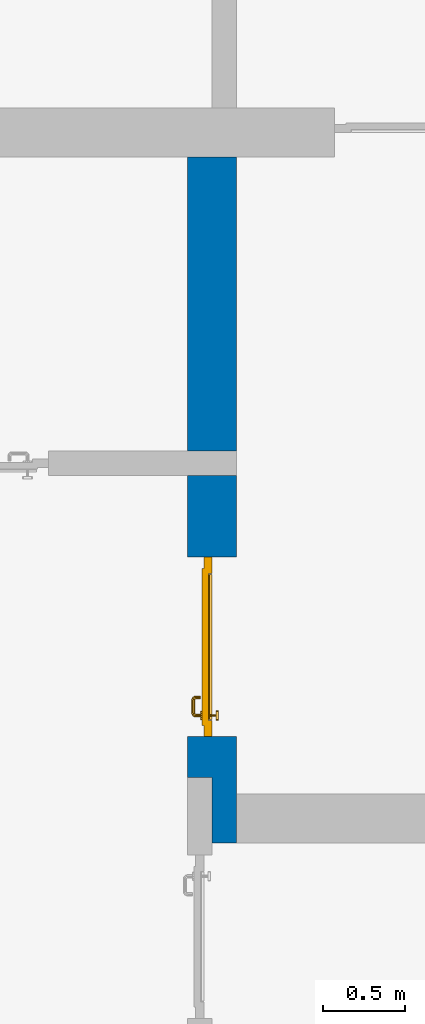
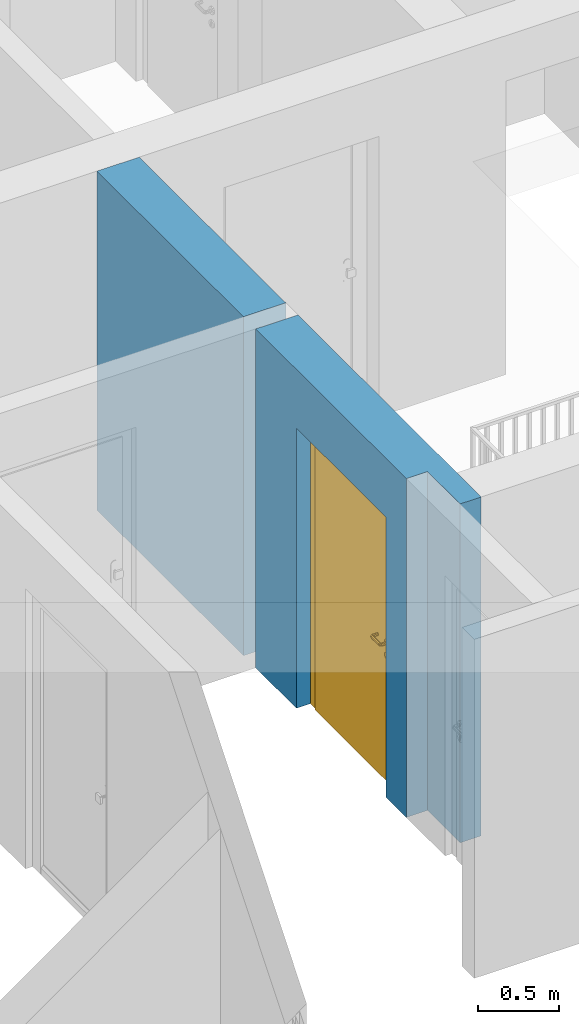
# One storey, part 13 of 54: 1 door, 1 wall, 1 opening.
"""IFC4 building model written with IfcOpenShell, lengths in metres."""

from ifc_helpers import new_model, entity, si_unit, converted_unit, derived_unit, direction, frame, origin_with_axes, place, context, subcontext, project, spatial, polygons, source, transform, mapped, material, type_object, element, fill, save


model = new_model("IFC4")

# Units and contexts
model_context = context("Model", 3, precision=1e-05, world=origin_with_axes(), true_north=direction((0.0, 1.0)))
body_context = subcontext(model_context, "Body", "Model", "MODEL_VIEW")
ifc_project = project(units=[si_unit("LENGTHUNIT", "METRE"), si_unit("AREAUNIT", "SQUARE_METRE"), si_unit("VOLUMEUNIT", "CUBIC_METRE"), converted_unit("PLANEANGLEUNIT", "DEGREE", entity("IfcPlaneAngleMeasure", 0.0174532925199), si_unit("PLANEANGLEUNIT", "RADIAN"), dimensions=[0, 0, 0, 0, 0, 0, 0]), converted_unit("TIMEUNIT", "Year", entity("IfcTimeMeasure", 31556926.0), si_unit("TIMEUNIT", "SECOND"), dimensions=[0, 0, 1, 0, 0, 0, 0]), si_unit("MASSUNIT", "GRAM", prefix="KILO"), si_unit("THERMODYNAMICTEMPERATUREUNIT", "DEGREE_CELSIUS"), si_unit("LUMINOUSINTENSITYUNIT", "LUMEN"), si_unit("ENERGYUNIT", "JOULE", prefix="MEGA"), derived_unit("THERMALCONDUCTANCEUNIT", [(si_unit("POWERUNIT", "WATT"), 1), (si_unit("LENGTHUNIT", "METRE"), -1), (si_unit("THERMODYNAMICTEMPERATUREUNIT", "KELVIN"), -1)]), derived_unit("SPECIFICHEATCAPACITYUNIT", [(si_unit("ENERGYUNIT", "JOULE"), 1), (si_unit("MASSUNIT", "GRAM", prefix="KILO"), -1), (si_unit("THERMODYNAMICTEMPERATUREUNIT", "KELVIN"), -1)]), derived_unit("MASSDENSITYUNIT", [(si_unit("MASSUNIT", "GRAM", prefix="KILO"), 1), (si_unit("VOLUMEUNIT", "CUBIC_METRE"), -1)])], contexts=[model_context])

# Site, building, storey
site_placement = place(None, origin_with_axes())
site = spatial("IfcSite", under=ifc_project, at=site_placement, CompositionType="ELEMENT")
building_placement = place(site_placement, origin_with_axes())
building = spatial("IfcBuilding", under=site, at=building_placement, CompositionType="ELEMENT")
storey_placement = place(building_placement, frame((0.0, 0.0, 6.29), z_axis=(0.0, 0.0, 1.0), x_axis=(1.0, 0.0, 0.0)))
storey = spatial("IfcBuildingStorey", under=building, at=storey_placement, Name="2. Geschoss", CompositionType="ELEMENT", Elevation=6.29)

# Wall, opening, door
ifc_material = material()
wall_type = type_object("IfcWallType", Name="300", PredefinedType="NOTDEFINED")
wall_placement = place(storey_placement, frame((-5.2421993804, -2.52881223104, 0.0), z_axis=(0.0, 0.0, 1.0), x_axis=(0.0, 1.0, 0.0)))
wall = element("IfcWall", 1, at=wall_placement, inside=storey, type_object=wall_type, material=ifc_material, Name="Wand-001", PredefinedType="NOTDEFINED", context=body_context, shape_type="Tessellation", body=[
    polygons([(0.35, -0.15, 2.1), (1.45, -0.15, 2.1), (1.45, -0.3, 2.1), (0.35, -0.3, 2.1), (0.35, 0.0, 2.1), (1.45, 0.0, 2.1), (1.45, -0.15, 0.0), (1.45, -0.3, 0.0), (1.95, -0.3, 2.54), (-0.3, -0.3, 2.54), (-0.3, -0.3, 0.0), (0.35, -0.3, 0.0), (1.95, -0.3, 0.0), (0.35, -0.15, 0.0), (0.35, 0.0, 0.0), (0.1, 0.0, 0.0), (0.1, 0.0, 2.54), (1.95, 0.0, 2.54), (1.95, 0.0, 0.0), (1.45, 0.0, 0.0), (-0.3, -0.15, 2.54), (0.1, -0.15, 2.54), (-0.3, -0.15, 0.0), (0.1, -0.15, 0.0)], [[[1, 2, 3, 4]], [[2, 1, 5, 6]], [[2, 7, 8, 3]], [[9, 10, 11, 12, 4, 3, 8, 13]], [[14, 1, 4, 12]], [[1, 14, 15, 5]], [[5, 15, 16, 17, 18, 19, 20, 6]], [[7, 2, 6, 20]], [[7, 20, 19, 13, 8]], [[21, 10, 9, 18, 17, 22]], [[21, 23, 11, 10]], [[15, 14, 12, 11, 23, 24, 16]], [[9, 13, 19, 18]], [[17, 16, 24, 22]], [[22, 24, 23, 21]]], closed=True),
    polygons([(3.9, 0.0, 0.0), (3.9, 0.0, 2.54), (3.9, -0.3, 2.54), (3.9, -0.3, 0.0), (2.1, 0.0, 0.0), (2.1, 0.0, 2.54), (2.1, -0.3, 2.54), (2.1, -0.3, 0.0)], [[[1, 2, 3, 4]], [[5, 6, 2, 1]], [[6, 7, 3, 2]], [[4, 3, 7, 8]], [[5, 1, 4, 8]], [[8, 7, 6, 5]]], closed=True),
])
opening_placement = place(wall_placement, frame((0.9, 0.0, 0.0), z_axis=(0.0, 0.0, 1.0), x_axis=(1.0, 0.0, 0.0)))
opening = element("IfcOpeningElement", 2, at=opening_placement, cuts=wall, context=body_context, identifier="Reference", shape_type="Tessellation", body=[
    polygons([(0.55, -0.15, 0.0), (0.55, -0.15, 2.1), (0.55, -0.301, 2.1), (0.55, -0.301, 0.0), (0.55, 0.001, 0.0), (0.55, 0.001, 2.1), (-0.55, -0.15, 2.1), (-0.55, -0.301, 2.1), (-0.55, 0.001, 2.1), (-0.55, -0.301, 0.0), (-0.55, -0.15, 0.0), (-0.55, 0.001, 0.0)], [[[1, 2, 3, 4]], [[2, 1, 5, 6]], [[7, 8, 3, 2, 6, 9]], [[8, 10, 4, 3]], [[1, 4, 10, 11, 12, 5]], [[6, 5, 12, 9]], [[7, 11, 10, 8]], [[11, 7, 9, 12]]], closed=True),
])
door_type = type_object("IfcDoorType", Name="Eingang 01 1-Fl 26", OperationType="SINGLE_SWING_RIGHT", PredefinedType="DOOR")
shared_shape = source(origin_with_axes(), body_context, "Body", "Tessellation", [
    polygons([(0.55, -0.05, 0.0), (0.55, -0.03, 0.0), (0.55, -0.03, 2.1), (0.55, -0.05, 2.1), (0.45, -0.05, 0.0), (0.45, -0.03, 0.0), (0.45, -0.03, 2.0), (0.1301, -0.03, 2.0), (0.0001, -0.03, 2.0), (-0.45, -0.03, 2.0), (-0.45, -0.03, 0.0), (-0.55, -0.03, 0.0), (-0.55, -0.03, 2.1), (-0.55, -0.05, 2.1), (-0.55, -0.05, 0.0), (-0.45, -0.05, 0.0), (-0.45, -0.05, 2.0), (0.0001, -0.05, 2.0), (0.1301, -0.05, 2.0), (0.45, -0.05, 2.0)], [[[1, 2, 3, 4]], [[5, 6, 2, 1]], [[2, 6, 7, 8, 9, 10, 11, 12, 13, 3]], [[4, 3, 13, 14]], [[1, 4, 14, 15, 16, 17, 18, 19, 20, 5]], [[20, 7, 6, 5]], [[19, 8, 7, 20]], [[18, 9, 8, 19]], [[17, 10, 9, 18]], [[16, 11, 10, 17]], [[15, 12, 11, 16]], [[14, 13, 12, 15]]], closed=True),
    polygons([(0.55, -0.03, 0.0), (0.55, 0.0, 0.0), (0.55, 0.0, 2.1), (0.55, -0.03, 2.1), (0.48, -0.03, 0.0), (0.48, 0.0, 0.0), (0.48, 0.0, 2.03), (0.1001, 0.0, 2.03), (0.0301, 0.0, 2.03), (-0.48, 0.0, 2.03), (-0.48, 0.0, 0.0), (-0.55, 0.0, 0.0), (-0.55, 0.0, 2.1), (-0.55, -0.03, 2.1), (-0.55, -0.03, 0.0), (-0.48, -0.03, 0.0), (-0.48, -0.03, 2.03), (0.0301, -0.03, 2.03), (0.1001, -0.03, 2.03), (0.48, -0.03, 2.03)], [[[1, 2, 3, 4]], [[5, 6, 2, 1]], [[2, 6, 7, 8, 9, 10, 11, 12, 13, 3]], [[4, 3, 13, 14]], [[1, 4, 14, 15, 16, 17, 18, 19, 20, 5]], [[20, 7, 6, 5]], [[19, 8, 7, 20]], [[18, 9, 8, 19]], [[17, 10, 9, 18]], [[16, 11, 10, 17]], [[15, 12, 11, 16]], [[14, 13, 12, 15]]], closed=True),
    polygons([(0.48, 0.01, 0.0), (-0.48, 0.01, 0.0), (-0.48, 0.01, 2.03), (0.48, 0.01, 2.03), (0.48, -0.03, 0.0), (-0.48, -0.03, 0.0), (-0.48, -0.03, 2.03), (0.48, -0.03, 2.03)], [[[1, 2, 3, 4]], [[2, 1, 5, 6]], [[3, 2, 6, 7]], [[4, 3, 7, 8]], [[1, 4, 8, 5]], [[6, 5, 8, 7]]], closed=True),
    polygons([(0.445, -0.05, 0.0), (0.445, -0.05, 0.05), (-0.445, -0.05, 0.05), (-0.445, -0.05, 0.0), (0.445, -0.03, 0.0), (0.445, -0.03, 0.07), (0.445, -0.035, 0.07), (-0.445, -0.035, 0.07), (-0.445, -0.03, 0.07), (-0.445, -0.03, 0.0)], [[[1, 2, 3, 4]], [[1, 5, 6, 7, 2]], [[2, 7, 8, 3]], [[4, 3, 8, 9, 10]], [[5, 1, 4, 10]], [[6, 5, 10, 9]], [[7, 6, 9, 8]]], closed=True),
    polygons([(-0.4335, 0.02, 1.0733826859), (-0.4335, 0.0199, 1.0733826859), (-0.42, 0.0199, 1.077), (-0.42, 0.02, 1.077), (-0.443382685902, 0.02, 1.0635), (-0.443382685902, 0.0199, 1.0635), (-0.4335, 0.0101, 1.0733826859), (-0.42, 0.0101, 1.077), (-0.4065, 0.0199, 1.0733826859), (-0.4065, 0.02, 1.0733826859), (-0.396617314098, 0.02, 1.0635), (-0.393, 0.02, 1.05), (-0.396617314098, 0.02, 1.0365), (-0.4065, 0.02, 1.0266173141), (-0.42, 0.02, 1.023), (-0.4335, 0.02, 1.0266173141), (-0.443382685902, 0.02, 1.0365), (-0.447, 0.02, 1.05), (-0.447, 0.0199, 1.05), (-0.443382685902, 0.0101, 1.0635), (-0.4335, 0.01, 1.0733826859), (-0.42, 0.01, 1.077), (-0.4065, 0.0101, 1.0733826859), (-0.396617314098, 0.0199, 1.0635), (-0.393, 0.0199, 1.05), (-0.396617314098, 0.0199, 1.0365), (-0.4065, 0.0199, 1.0266173141), (-0.42, 0.0199, 1.023), (-0.4335, 0.0199, 1.0266173141), (-0.443382685902, 0.0199, 1.0365), (-0.447, 0.0101, 1.05), (-0.443382685902, 0.01, 1.0635), (-0.447, 0.01, 1.05), (-0.443382685902, 0.01, 1.0365), (-0.4335, 0.01, 1.0266173141), (-0.42, 0.01, 1.023), (-0.4065, 0.01, 1.0266173141), (-0.396617314098, 0.01, 1.0365), (-0.393, 0.01, 1.05), (-0.396617314098, 0.01, 1.0635), (-0.4065, 0.01, 1.0733826859), (-0.396617314098, 0.0101, 1.0635), (-0.393, 0.0101, 1.05), (-0.396617314098, 0.0101, 1.0365), (-0.4065, 0.0101, 1.0266173141), (-0.42, 0.0101, 1.023), (-0.4335, 0.0101, 1.0266173141), (-0.443382685902, 0.0101, 1.0365)], [[[1, 2, 3, 4]], [[5, 6, 2, 1]], [[2, 7, 8, 3]], [[4, 3, 9, 10]], [[4, 10, 11, 12, 13, 14, 15, 16, 17, 18, 5, 1]], [[18, 19, 6, 5]], [[6, 20, 7, 2]], [[7, 21, 22, 8]], [[3, 8, 23, 9]], [[10, 9, 24, 11]], [[11, 24, 25, 12]], [[12, 25, 26, 13]], [[13, 26, 27, 14]], [[14, 27, 28, 15]], [[15, 28, 29, 16]], [[16, 29, 30, 17]], [[17, 30, 19, 18]], [[19, 31, 20, 6]], [[20, 32, 21, 7]], [[22, 21, 32, 33, 34, 35, 36, 37, 38, 39, 40, 41]], [[8, 22, 41, 23]], [[9, 23, 42, 24]], [[24, 42, 43, 25]], [[25, 43, 44, 26]], [[26, 44, 45, 27]], [[27, 45, 46, 28]], [[28, 46, 47, 29]], [[29, 47, 48, 30]], [[30, 48, 31, 19]], [[31, 33, 32, 20]], [[48, 34, 33, 31]], [[47, 35, 34, 48]], [[46, 36, 35, 47]], [[45, 37, 36, 46]], [[44, 38, 37, 45]], [[43, 39, 38, 44]], [[42, 40, 39, 43]], [[23, 41, 40, 42]]], closed=True),
    polygons([(-0.412532169224, 0.019, 0.959692280177), (-0.415, 0.019, 0.9544), (-0.415, 0.019, 0.952886751346), (-0.397569942042, 0.019, 0.96295), (-0.40705, 0.019, 0.972430057958), (-0.413279754556, 0.019, 0.961639806549), (-0.412532169224, 0.02, 0.959692280177), (-0.415, 0.02, 0.9544), (-0.415, 0.02, 0.952886751346), (-0.415, 0.02, 0.95), (-0.415, 0.02, 0.947113248654), (-0.415, 0.02, 0.941339745962), (-0.415, 0.02, 0.9375), (-0.415, 0.019, 0.9375), (-0.415, 0.019, 0.941339745962), (-0.415, 0.019, 0.947113248654), (-0.415, 0.019, 0.95), (-0.3941, 0.019, 0.95), (-0.397483339502, 0.019, 0.963), (-0.407, 0.019, 0.972516660498), (-0.414624817685, 0.019, 0.965143815798), (-0.42, 0.019, 0.9759), (-0.42, 0.019, 0.967425445323), (-0.414624817685, 0.02, 0.965143815798), (-0.413279754556, 0.02, 0.961639806549), (-0.40655, 0.02, 0.973296083362), (-0.396703916638, 0.02, 0.96345), (-0.3931, 0.02, 0.95), (-0.396703916638, 0.02, 0.93655), (-0.40655, 0.02, 0.926703916638), (-0.42, 0.02, 0.9231), (-0.42, 0.02, 0.9325), (-0.416464466094, 0.02, 0.933964466094), (-0.416464466094, 0.019, 0.933964466094), (-0.40705, 0.019, 0.927569942042), (-0.42, 0.019, 0.9325), (-0.42, 0.019, 0.9241), (-0.397569942042, 0.019, 0.93705), (-0.394, 0.019, 0.95), (-0.397483339502, 0.0189, 0.963), (-0.407, 0.0189, 0.972516660498), (-0.42, 0.019, 0.976), (-0.425375182315, 0.019, 0.965143815798), (-0.43295, 0.019, 0.972430057958), (-0.426720245444, 0.019, 0.961639806549), (-0.42, 0.02, 0.967425445323), (-0.42, 0.02, 0.9769), (-0.396617314098, 0.02, 0.9635), (-0.4065, 0.02, 0.973382685902), (-0.393, 0.02, 0.95), (-0.396617314098, 0.02, 0.9365), (-0.4065, 0.02, 0.926617314098), (-0.43345, 0.02, 0.926703916638), (-0.425, 0.02, 0.941339745962), (-0.425, 0.02, 0.9375), (-0.423535533906, 0.02, 0.933964466094), (-0.42, 0.02, 0.923), (-0.423535533906, 0.019, 0.933964466094), (-0.425, 0.019, 0.9375), (-0.425, 0.019, 0.941339745962), (-0.43295, 0.019, 0.927569942042), (-0.42, 0.019, 0.924), (-0.407, 0.019, 0.927483339502), (-0.397483339502, 0.019, 0.937), (-0.394, 0.0189, 0.95), (-0.397483339502, 0.0101, 0.963), (-0.407, 0.0101, 0.972516660498), (-0.42, 0.0189, 0.976), (-0.433, 0.019, 0.972516660498), (-0.425375182315, 0.02, 0.965143815798), (-0.427467830776, 0.019, 0.959692280177), (-0.442430057958, 0.019, 0.96295), (-0.425, 0.019, 0.952886751346), (-0.425, 0.019, 0.9544), (-0.427467830776, 0.02, 0.959692280177), (-0.426720245444, 0.02, 0.961639806549), (-0.43345, 0.02, 0.973296083362), (-0.42, 0.02, 0.977), (-0.396617314098, 0.0199, 0.9635), (-0.4065, 0.0199, 0.973382685902), (-0.393, 0.0199, 0.95), (-0.396617314098, 0.0199, 0.9365), (-0.4065, 0.0199, 0.926617314098), (-0.443296083362, 0.02, 0.93655), (-0.425, 0.02, 0.947113248654), (-0.425, 0.02, 0.9544), (-0.425, 0.019, 0.95), (-0.425, 0.019, 0.947113248654), (-0.425, 0.02, 0.95), (-0.425, 0.02, 0.952886751346), (-0.4335, 0.02, 0.926617314098), (-0.42, 0.0199, 0.923), (-0.442430057958, 0.019, 0.93705), (-0.433, 0.019, 0.927483339502), (-0.42, 0.0189, 0.924), (-0.407, 0.0189, 0.927483339502), (-0.397483339502, 0.0189, 0.937), (-0.394, 0.0101, 0.95), (-0.397483339502, 0.01, 0.963), (-0.407, 0.01, 0.972516660498), (-0.42, 0.0101, 0.976), (-0.433, 0.0189, 0.972516660498), (-0.442516660498, 0.019, 0.963), (-0.4459, 0.019, 0.95), (-0.443296083362, 0.02, 0.96345), (-0.4335, 0.02, 0.973382685902), (-0.42, 0.0199, 0.977), (-0.396617314098, 0.0101, 0.9635), (-0.4065, 0.0101, 0.973382685902), (-0.393, 0.0101, 0.95), (-0.396617314098, 0.0101, 0.9365), (-0.4065, 0.0101, 0.926617314098), (-0.443382685902, 0.02, 0.9365), (-0.4469, 0.02, 0.95), (-0.4335, 0.0199, 0.926617314098), (-0.42, 0.0101, 0.923), (-0.442516660498, 0.019, 0.937), (-0.433, 0.0189, 0.927483339502), (-0.42, 0.0101, 0.924), (-0.407, 0.0101, 0.927483339502), (-0.397483339502, 0.0101, 0.937), (-0.394, 0.01, 0.95), (-0.397396736961, 0.01, 0.96305), (-0.40695, 0.01, 0.972603263039), (-0.42, 0.01, 0.976), (-0.433, 0.0101, 0.972516660498), (-0.442516660498, 0.0189, 0.963), (-0.446, 0.019, 0.95), (-0.443382685902, 0.02, 0.9635), (-0.4335, 0.0199, 0.973382685902), (-0.42, 0.0101, 0.977), (-0.396617314098, 0.01, 0.9635), (-0.4065, 0.01, 0.973382685902), (-0.393, 0.01, 0.95), (-0.396617314098, 0.01, 0.9365), (-0.4065, 0.01, 0.926617314098), (-0.447, 0.02, 0.95), (-0.443382685902, 0.0199, 0.9365), (-0.4335, 0.0101, 0.926617314098), (-0.42, 0.01, 0.923), (-0.442516660498, 0.0189, 0.937), (-0.433, 0.0101, 0.927483339502), (-0.42, 0.01, 0.924), (-0.407, 0.01, 0.927483339502), (-0.397483339502, 0.01, 0.937), (-0.3939, 0.01, 0.95), (-0.396703916638, 0.01, 0.96345), (-0.40655, 0.01, 0.973296083362), (-0.42, 0.01, 0.9761), (-0.433, 0.01, 0.972516660498), (-0.442516660498, 0.0101, 0.963), (-0.446, 0.0189, 0.95), (-0.443382685902, 0.0199, 0.9635), (-0.4335, 0.0101, 0.973382685902), (-0.42, 0.01, 0.977), (-0.3931, 0.01, 0.95), (-0.396703916638, 0.01, 0.93655), (-0.40655, 0.01, 0.926703916638), (-0.447, 0.0199, 0.95), (-0.443382685902, 0.0101, 0.9365), (-0.4335, 0.01, 0.926617314098), (-0.42, 0.01, 0.9231), (-0.442516660498, 0.0101, 0.937), (-0.433, 0.01, 0.927483339502), (-0.42, 0.01, 0.9239), (-0.40695, 0.01, 0.927396736961), (-0.397396736961, 0.01, 0.93695), (-0.42, 0.01, 0.9769), (-0.43305, 0.01, 0.972603263039), (-0.442516660498, 0.01, 0.963), (-0.446, 0.0101, 0.95), (-0.443382685902, 0.0101, 0.9635), (-0.4335, 0.01, 0.973382685902), (-0.447, 0.0101, 0.95), (-0.443382685902, 0.01, 0.9365), (-0.43345, 0.01, 0.926703916638), (-0.442516660498, 0.01, 0.937), (-0.43305, 0.01, 0.927396736961), (-0.43345, 0.01, 0.973296083362), (-0.442603263039, 0.01, 0.96305), (-0.446, 0.01, 0.95), (-0.443382685902, 0.01, 0.9635), (-0.447, 0.01, 0.95), (-0.443296083362, 0.01, 0.93655), (-0.442603263039, 0.01, 0.93695), (-0.443296083362, 0.01, 0.96345), (-0.4461, 0.01, 0.95), (-0.4469, 0.01, 0.95)], [[[1, 2, 3, 4, 5, 6]], [[2, 1, 7, 8]], [[2, 8, 9, 10, 11, 12, 13, 14, 15, 16, 17, 3]], [[17, 18, 4, 3]], [[4, 19, 20, 5]], [[21, 6, 5, 22, 23]], [[1, 6, 21, 24, 25, 7]], [[7, 25, 26, 27, 9, 8]], [[9, 27, 28, 10]], [[10, 28, 29, 11]], [[11, 29, 30, 12]], [[31, 32, 33, 13, 12, 30]], [[14, 13, 33, 34]], [[35, 15, 14, 34, 36, 37]], [[15, 35, 38, 16]], [[16, 38, 18, 17]], [[18, 39, 19, 4]], [[19, 40, 41, 20]], [[5, 20, 42, 22]], [[43, 23, 22, 44, 45]], [[21, 23, 46, 24]], [[24, 46, 47, 26, 25]], [[48, 27, 26, 49]], [[50, 28, 27, 48]], [[51, 29, 28, 50]], [[52, 30, 29, 51]], [[53, 54, 55, 56, 32, 31]], [[34, 33, 32, 36]], [[57, 31, 30, 52]], [[37, 36, 58, 59, 60, 61]], [[37, 62, 63, 35]], [[35, 63, 64, 38]], [[38, 64, 39, 18]], [[39, 65, 40, 19]], [[40, 66, 67, 41]], [[20, 41, 68, 42]], [[22, 42, 69, 44]], [[23, 43, 70, 46]], [[71, 45, 44, 72, 73, 74]], [[43, 45, 71, 75, 76, 70]], [[70, 76, 77, 47, 46]], [[49, 26, 47, 78]], [[79, 48, 49, 80]], [[81, 50, 48, 79]], [[82, 51, 50, 81]], [[83, 52, 51, 82]], [[54, 53, 84, 85]], [[86, 74, 73, 87, 88, 60, 59, 55, 54, 85, 89, 90]], [[58, 56, 55, 59]], [[36, 32, 56, 58]], [[91, 53, 31, 57]], [[92, 57, 52, 83]], [[88, 93, 61, 60]], [[61, 94, 62, 37]], [[62, 95, 96, 63]], [[63, 96, 97, 64]], [[64, 97, 65, 39]], [[65, 98, 66, 40]], [[66, 99, 100, 67]], [[41, 67, 101, 68]], [[42, 68, 102, 69]], [[44, 69, 103, 72]], [[73, 72, 104, 87]], [[71, 74, 86, 75]], [[75, 86, 90, 105, 77, 76]], [[78, 47, 77, 106]], [[80, 49, 78, 107]], [[108, 79, 80, 109]], [[110, 81, 79, 108]], [[111, 82, 81, 110]], [[112, 83, 82, 111]], [[113, 84, 53, 91]], [[85, 84, 114, 89]], [[87, 104, 93, 88]], [[89, 114, 105, 90]], [[115, 91, 57, 92]], [[116, 92, 83, 112]], [[93, 117, 94, 61]], [[94, 118, 95, 62]], [[95, 119, 120, 96]], [[96, 120, 121, 97]], [[97, 121, 98, 65]], [[98, 122, 99, 66]], [[99, 123, 124, 100]], [[67, 100, 125, 101]], [[68, 101, 126, 102]], [[69, 102, 127, 103]], [[72, 103, 128, 104]], [[106, 77, 105, 129]], [[107, 78, 106, 130]], [[109, 80, 107, 131]], [[132, 108, 109, 133]], [[134, 110, 108, 132]], [[135, 111, 110, 134]], [[136, 112, 111, 135]], [[137, 114, 84, 113]], [[138, 113, 91, 115]], [[104, 128, 117, 93]], [[129, 105, 114, 137]], [[139, 115, 92, 116]], [[140, 116, 112, 136]], [[117, 141, 118, 94]], [[118, 142, 119, 95]], [[119, 143, 144, 120]], [[120, 144, 145, 121]], [[121, 145, 122, 98]], [[122, 146, 123, 99]], [[123, 147, 148, 124]], [[100, 124, 149, 125]], [[101, 125, 150, 126]], [[102, 126, 151, 127]], [[103, 127, 152, 128]], [[130, 106, 129, 153]], [[131, 107, 130, 154]], [[133, 109, 131, 155]], [[147, 132, 133, 148]], [[156, 134, 132, 147]], [[157, 135, 134, 156]], [[158, 136, 135, 157]], [[159, 137, 113, 138]], [[160, 138, 115, 139]], [[128, 152, 141, 117]], [[153, 129, 137, 159]], [[161, 139, 116, 140]], [[162, 140, 136, 158]], [[141, 163, 142, 118]], [[142, 164, 143, 119]], [[143, 165, 166, 144]], [[144, 166, 167, 145]], [[145, 167, 146, 122]], [[146, 156, 147, 123]], [[124, 148, 168, 149]], [[125, 149, 169, 150]], [[126, 150, 170, 151]], [[127, 151, 171, 152]], [[154, 130, 153, 172]], [[155, 131, 154, 173]], [[148, 133, 155, 168]], [[167, 157, 156, 146]], [[166, 158, 157, 167]], [[174, 159, 138, 160]], [[175, 160, 139, 161]], [[152, 171, 163, 141]], [[172, 153, 159, 174]], [[176, 161, 140, 162]], [[165, 162, 158, 166]], [[163, 177, 164, 142]], [[164, 178, 165, 143]], [[149, 168, 179, 169]], [[150, 169, 180, 170]], [[151, 170, 181, 171]], [[173, 154, 172, 182]], [[168, 155, 173, 179]], [[183, 174, 160, 175]], [[184, 175, 161, 176]], [[171, 181, 177, 163]], [[182, 172, 174, 183]], [[178, 176, 162, 165]], [[177, 185, 178, 164]], [[169, 179, 186, 180]], [[170, 180, 187, 181]], [[179, 173, 182, 186]], [[188, 183, 175, 184]], [[185, 184, 176, 178]], [[181, 187, 185, 177]], [[186, 182, 183, 188]], [[180, 186, 188, 187]], [[187, 188, 184, 185]]], closed=True),
    polygons([(-0.43, 0.02, 1.05), (-0.43, 0.0509849140336, 1.05), (-0.427071067812, 0.050696439392, 1.04292893219), (-0.427071067812, 0.02, 1.04292893219), (-0.427071067812, 0.02, 1.05707106781), (-0.427071067812, 0.050696439392, 1.05707106781), (-0.428277987014, 0.0596420579258, 1.05), (-0.425518993221, 0.0584992452783, 1.04292893219), (-0.42, 0.05, 1.04), (-0.42, 0.02, 1.04), (-0.42, 0.02, 1.06), (-0.42, 0.05, 1.06), (-0.425518993221, 0.0584992452783, 1.05707106781), (-0.422816199938, 0.0678161999379, 1.05), (-0.420704557509, 0.0657045575088, 1.04292893219), (-0.418858192988, 0.0557402514855, 1.04), (-0.412928932188, 0.049303560608, 1.04292893219), (-0.412928932188, 0.02, 1.04292893219), (-0.412928932188, 0.02, 1.05707106781), (-0.412928932188, 0.049303560608, 1.05707106781), (-0.418858192988, 0.0557402514855, 1.06), (-0.420704557509, 0.0657045575088, 1.05707106781), (-0.414642057926, 0.0732779870137, 1.05), (-0.413499245278, 0.0705189932208, 1.04292893219), (-0.415606601718, 0.0606066017178, 1.04), (-0.412197392755, 0.0529812576926, 1.04292893219), (-0.41, 0.0490150859664, 1.05), (-0.41, 0.02, 1.05), (-0.412197392755, 0.0529812576926, 1.05707106781), (-0.415606601718, 0.0606066017178, 1.06), (-0.413499245278, 0.0705189932208, 1.05707106781), (-0.405984914034, 0.075, 1.05), (-0.405696439392, 0.0720710678119, 1.04292893219), (-0.410740251485, 0.0638581929877, 1.04), (-0.410508645927, 0.0555086459268, 1.04292893219), (-0.409438398962, 0.0518384450452, 1.05), (-0.410508645927, 0.0555086459268, 1.05707106781), (-0.410740251485, 0.0638581929877, 1.06), (-0.405696439392, 0.0720710678119, 1.05707106781), (-0.324015085966, 0.075, 1.05), (-0.324303560608, 0.0720710678119, 1.04292893219), (-0.405, 0.065, 1.04), (-0.407981257693, 0.0571973927545, 1.04292893219), (-0.408397003498, 0.0533970034977, 1.05), (-0.407981257693, 0.0571973927545, 1.05707106781), (-0.405, 0.065, 1.06), (-0.324303560608, 0.0720710678119, 1.05707106781), (-0.315357942074, 0.0732779870137, 1.05), (-0.316500754722, 0.0705189932208, 1.04292893219), (-0.325, 0.065, 1.04), (-0.404303560608, 0.0579289321881, 1.04292893219), (-0.406838445045, 0.0544383989617, 1.05), (-0.404303560608, 0.0579289321881, 1.05707106781), (-0.325, 0.065, 1.06), (-0.316500754722, 0.0705189932208, 1.05707106781), (-0.307183800062, 0.0678161999379, 1.05), (-0.309295442491, 0.0657045575088, 1.04292893219), (-0.319259748515, 0.0638581929877, 1.04), (-0.325696439392, 0.0579289321881, 1.04292893219), (-0.404015085966, 0.055, 1.05), (-0.325696439392, 0.0579289321881, 1.05707106781), (-0.319259748515, 0.0638581929877, 1.06), (-0.309295442491, 0.0657045575088, 1.05707106781), (-0.301722012986, 0.0596420579258, 1.05), (-0.304481006779, 0.0584992452783, 1.04292893219), (-0.314393398282, 0.0606066017178, 1.04), (-0.322018742307, 0.0571973927545, 1.04292893219), (-0.325984914034, 0.055, 1.05), (-0.322018742307, 0.0571973927545, 1.05707106781), (-0.314393398282, 0.0606066017178, 1.06), (-0.304481006779, 0.0584992452783, 1.05707106781), (-0.3, 0.0509849140336, 1.05), (-0.302928932188, 0.050696439392, 1.04292893219), (-0.311141807012, 0.0557402514855, 1.04), (-0.319491354073, 0.0555086459268, 1.04292893219), (-0.323161554955, 0.0544383989617, 1.05), (-0.319491354073, 0.0555086459268, 1.05707106781), (-0.311141807012, 0.0557402514855, 1.06), (-0.302928932188, 0.050696439392, 1.05707106781), (-0.3, 0.02, 1.05), (-0.302928932188, 0.02, 1.04292893219), (-0.31, 0.05, 1.04), (-0.317802607245, 0.0529812576926, 1.04292893219), (-0.321602996502, 0.0533970034977, 1.05), (-0.317802607245, 0.0529812576926, 1.05707106781), (-0.31, 0.05, 1.06), (-0.302928932188, 0.02, 1.05707106781), (-0.31, 0.02, 1.06), (-0.317071067812, 0.02, 1.05707106781), (-0.32, 0.02, 1.05), (-0.317071067812, 0.02, 1.04292893219), (-0.31, 0.02, 1.04), (-0.317071067812, 0.049303560608, 1.04292893219), (-0.320561601038, 0.0518384450452, 1.05), (-0.317071067812, 0.049303560608, 1.05707106781), (-0.32, 0.0490150859664, 1.05)], [[[1, 2, 3, 4]], [[5, 6, 2, 1]], [[2, 7, 8, 3]], [[4, 3, 9, 10]], [[11, 12, 6, 5]], [[6, 13, 7, 2]], [[7, 14, 15, 8]], [[3, 8, 16, 9]], [[10, 9, 17, 18]], [[19, 20, 12, 11]], [[12, 21, 13, 6]], [[13, 22, 14, 7]], [[14, 23, 24, 15]], [[8, 15, 25, 16]], [[9, 16, 26, 17]], [[18, 17, 27, 28]], [[28, 27, 20, 19]], [[20, 29, 21, 12]], [[21, 30, 22, 13]], [[22, 31, 23, 14]], [[23, 32, 33, 24]], [[15, 24, 34, 25]], [[16, 25, 35, 26]], [[17, 26, 36, 27]], [[27, 36, 29, 20]], [[29, 37, 30, 21]], [[30, 38, 31, 22]], [[31, 39, 32, 23]], [[32, 40, 41, 33]], [[24, 33, 42, 34]], [[25, 34, 43, 35]], [[26, 35, 44, 36]], [[36, 44, 37, 29]], [[37, 45, 38, 30]], [[38, 46, 39, 31]], [[39, 47, 40, 32]], [[40, 48, 49, 41]], [[33, 41, 50, 42]], [[34, 42, 51, 43]], [[35, 43, 52, 44]], [[44, 52, 45, 37]], [[45, 53, 46, 38]], [[46, 54, 47, 39]], [[47, 55, 48, 40]], [[48, 56, 57, 49]], [[41, 49, 58, 50]], [[42, 50, 59, 51]], [[43, 51, 60, 52]], [[52, 60, 53, 45]], [[53, 61, 54, 46]], [[54, 62, 55, 47]], [[55, 63, 56, 48]], [[56, 64, 65, 57]], [[49, 57, 66, 58]], [[50, 58, 67, 59]], [[51, 59, 68, 60]], [[60, 68, 61, 53]], [[61, 69, 62, 54]], [[62, 70, 63, 55]], [[63, 71, 64, 56]], [[64, 72, 73, 65]], [[57, 65, 74, 66]], [[58, 66, 75, 67]], [[59, 67, 76, 68]], [[68, 76, 69, 61]], [[69, 77, 70, 62]], [[70, 78, 71, 63]], [[71, 79, 72, 64]], [[72, 80, 81, 73]], [[65, 73, 82, 74]], [[66, 74, 83, 75]], [[67, 75, 84, 76]], [[76, 84, 77, 69]], [[77, 85, 78, 70]], [[78, 86, 79, 71]], [[79, 87, 80, 72]], [[80, 87, 88, 89, 90, 91, 92, 81]], [[73, 81, 92, 82]], [[74, 82, 93, 83]], [[75, 83, 94, 84]], [[84, 94, 85, 77]], [[85, 95, 86, 78]], [[86, 88, 87, 79]], [[95, 89, 88, 86]], [[96, 90, 89, 95]], [[93, 91, 90, 96]], [[82, 92, 91, 93]], [[83, 93, 96, 94]], [[94, 96, 95, 85]]], closed=False),
    polygons([(-0.414696699141, -0.035, 1.04469669914), (-0.42, -0.035, 1.0425), (-0.425303300859, -0.035, 1.04469669914), (-0.4275, -0.035, 1.05), (-0.425303300859, -0.035, 1.05530330086), (-0.42, -0.035, 1.0575), (-0.414696699141, -0.035, 1.05530330086), (-0.4125, -0.035, 1.05), (-0.414696699141, -0.075, 1.04469669914), (-0.42, -0.075, 1.0425), (-0.425303300859, -0.075, 1.04469669914), (-0.4275, -0.075, 1.05), (-0.425303300859, -0.075, 1.05530330086), (-0.42, -0.075, 1.0575), (-0.414696699141, -0.075, 1.05530330086), (-0.4125, -0.075, 1.05)], [[[1, 2, 3, 4, 5, 6, 7, 8]], [[2, 1, 9, 10]], [[3, 2, 10, 11]], [[4, 3, 11, 12]], [[5, 4, 12, 13]], [[6, 5, 13, 14]], [[7, 6, 14, 15]], [[8, 7, 15, 16]], [[1, 8, 16, 9]], [[9, 16, 15, 14, 13, 12, 11, 10]]], closed=True),
    polygons([(-0.445, -0.03, 0.975), (-0.443096988313, -0.03, 0.965432914191), (-0.443096988313, -0.035, 0.965432914191), (-0.445, -0.035, 0.975), (-0.445, -0.03, 1.1), (-0.443096988313, -0.03, 1.10956708581), (-0.43767766953, -0.03, 1.11767766953), (-0.429567085809, -0.03, 1.12309698831), (-0.42, -0.03, 1.125), (-0.410432914191, -0.03, 1.12309698831), (-0.40232233047, -0.03, 1.11767766953), (-0.396903011687, -0.03, 1.10956708581), (-0.395, -0.03, 1.1), (-0.395, -0.03, 0.975), (-0.396903011687, -0.03, 0.965432914191), (-0.40232233047, -0.03, 0.95732233047), (-0.410432914191, -0.03, 0.951903011687), (-0.42, -0.03, 0.95), (-0.429567085809, -0.03, 0.951903011687), (-0.43767766953, -0.03, 0.95732233047), (-0.43767766953, -0.035, 0.95732233047), (-0.429567085809, -0.035, 0.951903011687), (-0.42, -0.035, 0.95), (-0.410432914191, -0.035, 0.951903011687), (-0.40232233047, -0.035, 0.95732233047), (-0.396903011687, -0.035, 0.965432914191), (-0.395, -0.035, 0.975), (-0.395, -0.035, 1.1), (-0.396903011687, -0.035, 1.10956708581), (-0.40232233047, -0.035, 1.11767766953), (-0.410432914191, -0.035, 1.12309698831), (-0.42, -0.035, 1.125), (-0.429567085809, -0.035, 1.12309698831), (-0.43767766953, -0.035, 1.11767766953), (-0.443096988313, -0.035, 1.10956708581), (-0.445, -0.035, 1.1)], [[[1, 2, 3, 4]], [[1, 5, 6, 7, 8, 9, 10, 11, 12, 13, 14, 15, 16, 17, 18, 19, 20, 2]], [[2, 20, 21, 3]], [[4, 3, 21, 22, 23, 24, 25, 26, 27, 28, 29, 30, 31, 32, 33, 34, 35, 36]], [[5, 1, 4, 36]], [[6, 5, 36, 35]], [[7, 6, 35, 34]], [[8, 7, 34, 33]], [[9, 8, 33, 32]], [[10, 9, 32, 31]], [[11, 10, 31, 30]], [[12, 11, 30, 29]], [[13, 12, 29, 28]], [[14, 13, 28, 27]], [[15, 14, 27, 26]], [[16, 15, 26, 25]], [[17, 16, 25, 24]], [[18, 17, 24, 23]], [[19, 18, 23, 22]], [[20, 19, 22, 21]]], closed=True),
    polygons([(-0.44, -0.075, 1.08), (-0.445, -0.075, 1.07866025404), (-0.445, -0.09, 1.07866025404), (-0.44, -0.09, 1.08), (-0.4, -0.075, 1.08), (-0.395, -0.075, 1.07866025404), (-0.391339745962, -0.075, 1.075), (-0.39, -0.075, 1.07), (-0.39, -0.075, 1.03), (-0.391339745962, -0.075, 1.025), (-0.395, -0.075, 1.02133974596), (-0.4, -0.075, 1.02), (-0.44, -0.075, 1.02), (-0.445, -0.075, 1.02133974596), (-0.448660254038, -0.075, 1.025), (-0.45, -0.075, 1.03), (-0.45, -0.075, 1.07), (-0.448660254038, -0.075, 1.075), (-0.448660254038, -0.09, 1.075), (-0.45, -0.09, 1.07), (-0.45, -0.09, 1.03), (-0.448660254038, -0.09, 1.025), (-0.445, -0.09, 1.02133974596), (-0.44, -0.09, 1.02), (-0.4, -0.09, 1.02), (-0.395, -0.09, 1.02133974596), (-0.391339745962, -0.09, 1.025), (-0.39, -0.09, 1.03), (-0.39, -0.09, 1.07), (-0.391339745962, -0.09, 1.075), (-0.395, -0.09, 1.07866025404), (-0.4, -0.09, 1.08)], [[[1, 2, 3, 4]], [[1, 5, 6, 7, 8, 9, 10, 11, 12, 13, 14, 15, 16, 17, 18, 2]], [[2, 18, 19, 3]], [[4, 3, 19, 20, 21, 22, 23, 24, 25, 26, 27, 28, 29, 30, 31, 32]], [[5, 1, 4, 32]], [[6, 5, 32, 31]], [[7, 6, 31, 30]], [[8, 7, 30, 29]], [[9, 8, 29, 28]], [[10, 9, 28, 27]], [[11, 10, 27, 26]], [[12, 11, 26, 25]], [[13, 12, 25, 24]], [[14, 13, 24, 23]], [[15, 14, 23, 22]], [[16, 15, 22, 21]], [[17, 16, 21, 20]], [[18, 17, 20, 19]]], closed=True),
])
door_placement = place(opening_placement, frame((-0.45, 0.0, 0.0), z_axis=(0.0, 0.0, 1.0), x_axis=(1.0, 0.0, 0.0)))
door = element("IfcDoor", 3, at=door_placement, inside=storey, type_object=door_type, OverallHeight=2.1, OverallWidth=1.1, PredefinedType="DOOR", context=body_context, shape_type="MappedRepresentation", body=[
    mapped(shared_shape, transform((0.45, -0.1, 0.0))),
])
fill(opening, door)

save(model, "model.ifc")
